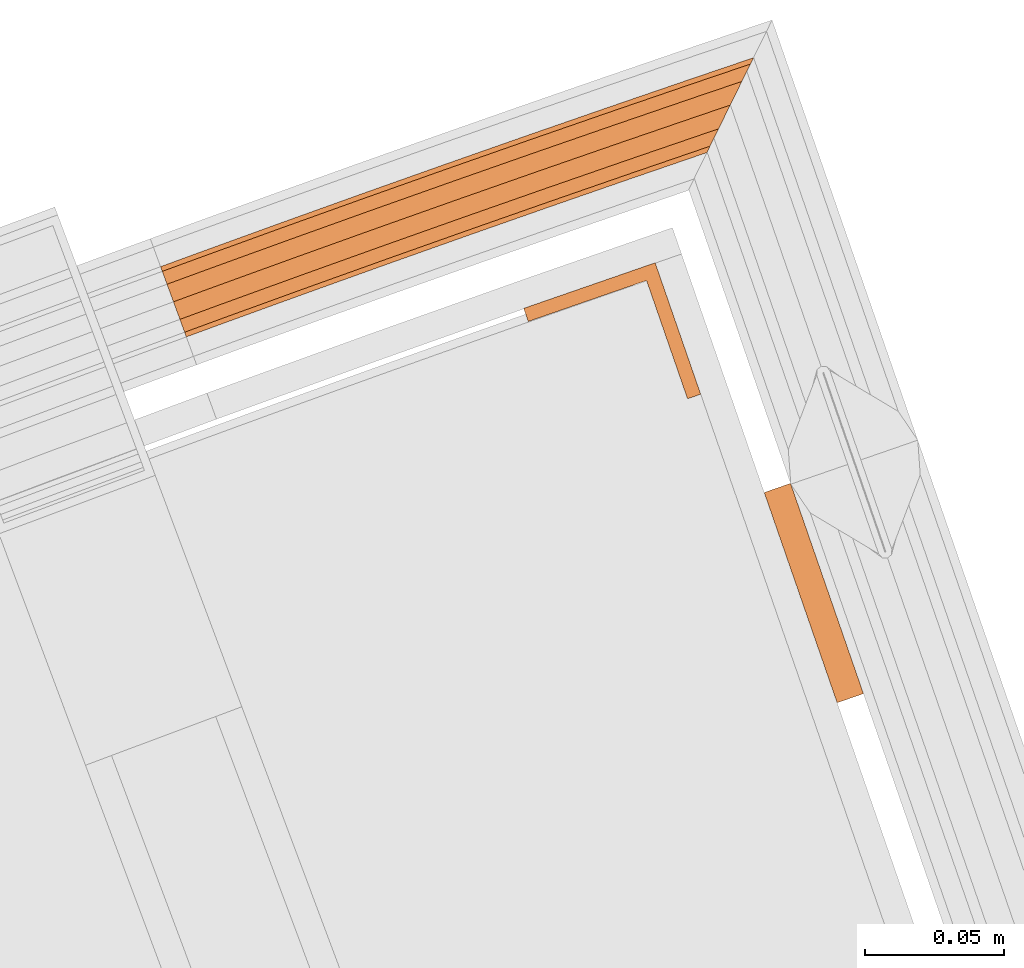
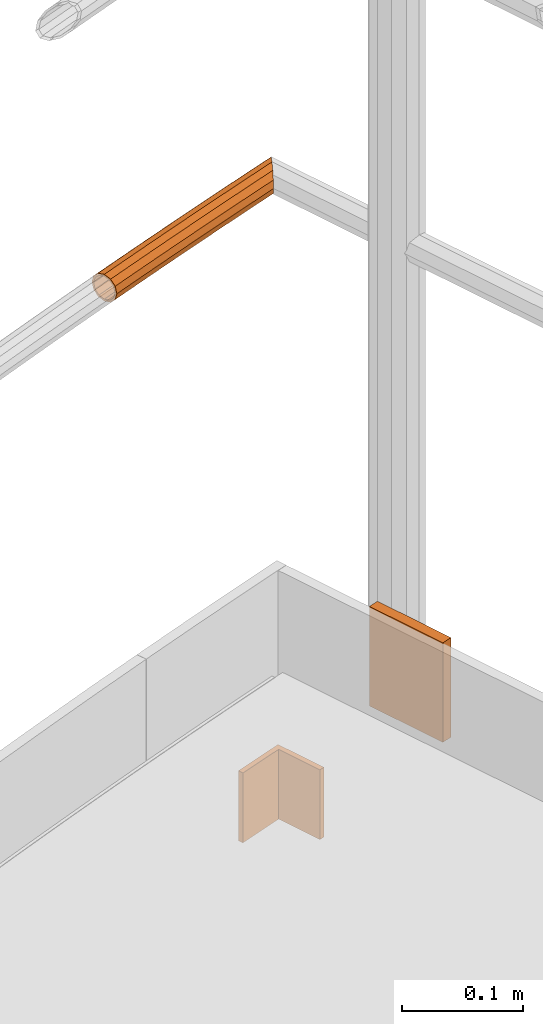
# One storey, part 103 of 126: 3 proxies.
"""IFC2X3 building model written with IfcOpenShell, lengths in millimetres."""

from ifc_helpers import new_model, si_unit, origin, origin_with_axes, place, context, project, spatial, faceted_brep, material, element, save


model = new_model("IFC2X3")

# Units and contexts
context_of_model_1 = context(None, 3, precision=0.1, world=origin())
context_of_model_2 = context(None, 3, precision=0.1, world=origin())
ifc_project = project(units=[si_unit("LENGTHUNIT", "METRE", prefix="MILLI"), si_unit("AREAUNIT", "SQUARE_METRE", prefix="CENTI"), si_unit("VOLUMEUNIT", "CUBIC_METRE", prefix="CENTI"), si_unit("MASSUNIT", "GRAM", prefix="KILO")], contexts=[context_of_model_1, context_of_model_2])

# Site, building, storey
site_placement = place(None, origin_with_axes())
site = spatial("IfcSite", under=ifc_project, at=site_placement, CompositionType="ELEMENT")
building_placement = place(site_placement, origin_with_axes())
building = spatial("IfcBuilding", under=site, at=building_placement, CompositionType="ELEMENT")
storey_placement = place(building_placement, origin_with_axes())
storey = spatial("IfcBuildingStorey", under=building, at=storey_placement, CompositionType="ELEMENT")

# Proxies
ifc_material = material(Name="S235JRG2")
proxy_1_placement = place(storey_placement, origin_with_axes())
element("IfcBuildingElementProxy", 1, at=proxy_1_placement, inside=storey, material=ifc_material, context=context_of_model_2, shape_type="Brep", body=[
    faceted_brep([(4962.9055, 16344.965, 11538.155), (4963.523, 16343.272, 11531.43), (4948.9781, 16337.938, 11531.43), (4948.3576, 16339.63, 11538.155), (4965.21, 16338.647, 11526.507), (4950.6731, 16333.316, 11526.507), (4967.5145, 16332.33, 11524.705), (4952.9885, 16327.002, 11524.705), (4969.819, 16326.012, 11526.507), (4955.304, 16320.689, 11526.507), (4971.506, 16321.387, 11531.43), (4956.999, 16316.066, 11531.43), (4972.1235, 16319.694, 11538.155), (4957.6195, 16314.375, 11538.155), (4971.506, 16321.387, 11544.88), (4956.999, 16316.066, 11544.88), (4969.819, 16326.012, 11549.803), (4955.304, 16320.689, 11549.803), (4967.5145, 16332.33, 11551.605), (4952.9885, 16327.002, 11551.605), (4965.21, 16338.647, 11549.803), (4950.6731, 16333.316, 11549.803), (4963.523, 16343.272, 11544.88), (4948.9781, 16337.938, 11544.88), (4963.5909, 16343.086, 11538.155), (4964.1165, 16341.645, 11543.88), (4949.5744, 16336.312, 11543.88), (4949.0462, 16337.752, 11538.155), (4965.5527, 16337.708, 11548.071), (4951.0174, 16332.377, 11548.071), (4967.5145, 16332.33, 11549.605), (4952.9885, 16327.002, 11549.605), (4969.4763, 16326.951, 11548.071), (4954.9597, 16321.627, 11548.071), (4970.9125, 16323.014, 11543.88), (4956.4027, 16317.693, 11543.88), (4971.4382, 16321.573, 11538.155), (4956.9308, 16316.252, 11538.155), (4970.9125, 16323.014, 11532.43), (4956.4027, 16317.693, 11532.43), (4969.4763, 16326.951, 11528.239), (4954.9597, 16321.627, 11528.239), (4967.5145, 16332.33, 11526.705), (4952.9885, 16327.002, 11526.705), (4965.5527, 16337.708, 11528.239), (4951.0174, 16332.377, 11528.239), (4964.1165, 16341.645, 11532.43), (4949.5744, 16336.312, 11532.43), (4992.036, 16355.533, 11538.155), (4992.6475, 16353.838, 11531.43), (4994.3184, 16349.208, 11526.507), (4996.6008, 16342.882, 11524.705), (4998.8833, 16336.556, 11526.507), (5000.5541, 16331.925, 11531.43), (5001.1657, 16330.23, 11538.155), (5000.5541, 16331.925, 11544.88), (4998.8833, 16336.556, 11549.803), (4996.6008, 16342.882, 11551.605), (4994.3184, 16349.208, 11549.803), (4992.6475, 16353.838, 11544.88), (4992.7148, 16353.652, 11538.155), (4993.2354, 16352.209, 11543.88), (4994.6578, 16348.267, 11548.071), (4996.6008, 16342.882, 11549.605), (4998.5439, 16337.496, 11548.071), (4999.9663, 16333.554, 11543.88), (5000.4869, 16332.111, 11538.155), (4999.9663, 16333.554, 11532.43), (4998.5439, 16337.496, 11528.239), (4996.6008, 16342.882, 11526.705), (4994.6578, 16348.267, 11528.239), (4993.2354, 16352.209, 11532.43), (5021.2031, 16366.0, 11538.155), (5021.8088, 16364.303, 11531.43), (5023.4635, 16359.666, 11526.507), (5025.7238, 16353.332, 11524.705), (5027.9841, 16346.998, 11526.507), (5029.6388, 16342.362, 11531.43), (5030.2445, 16340.665, 11538.155), (5029.6388, 16342.362, 11544.88), (5027.9841, 16346.998, 11549.803), (5025.7238, 16353.332, 11551.605), (5023.4635, 16359.666, 11549.803), (5021.8088, 16364.303, 11544.88), (5021.8753, 16364.116, 11538.155), (5022.3909, 16362.671, 11543.88), (5023.7996, 16358.724, 11548.071), (5025.7238, 16353.332, 11549.605), (5027.648, 16347.94, 11548.071), (5029.0567, 16343.993, 11543.88), (5029.5723, 16342.548, 11538.155), (5029.0567, 16343.993, 11532.43), (5027.648, 16347.94, 11528.239), (5025.7238, 16353.332, 11526.705), (5023.7996, 16358.724, 11528.239), (5022.3909, 16362.671, 11532.43), (5050.4066, 16376.364, 11538.155), (5051.0064, 16374.665, 11531.43), (5052.6448, 16370.022, 11526.507), (5054.8831, 16363.681, 11524.705), (5057.1213, 16357.339, 11526.507), (5058.7598, 16352.697, 11531.43), (5059.3595, 16350.998, 11538.155), (5058.7598, 16352.697, 11544.88), (5057.1213, 16357.339, 11549.803), (5054.8831, 16363.681, 11551.605), (5052.6448, 16370.022, 11549.803), (5051.0064, 16374.665, 11544.88), (5051.0723, 16374.478, 11538.155), (5051.5828, 16373.031, 11543.88), (5052.9777, 16369.08, 11548.071), (5054.8831, 16363.681, 11549.605), (5056.7885, 16358.282, 11548.071), (5058.1833, 16354.33, 11543.88), (5058.6939, 16352.884, 11538.155), (5058.1833, 16354.33, 11532.43), (5056.7885, 16358.282, 11528.239), (5054.8831, 16363.681, 11526.705), (5052.9777, 16369.08, 11528.239), (5051.5828, 16373.031, 11532.43), (5079.6461, 16386.626, 11538.155), (5080.2399, 16384.925, 11531.43), (5081.8622, 16380.277, 11526.507), (5084.0783, 16373.928, 11524.705), (5086.2943, 16367.578, 11526.507), (5087.9166, 16362.93, 11531.43), (5088.5104, 16361.229, 11538.155), (5087.9166, 16362.93, 11544.88), (5086.2943, 16367.578, 11549.803), (5084.0783, 16373.928, 11551.605), (5081.8622, 16380.277, 11549.803), (5080.2399, 16384.925, 11544.88), (5080.3052, 16384.738, 11538.155), (5080.8107, 16383.29, 11543.88), (5082.1917, 16379.333, 11548.071), (5084.0783, 16373.928, 11549.605), (5085.9648, 16368.522, 11548.071), (5087.3459, 16364.566, 11543.88), (5087.8514, 16363.117, 11538.155), (5087.3459, 16364.566, 11532.43), (5085.9648, 16368.522, 11528.239), (5084.0783, 16373.928, 11526.705), (5082.1917, 16379.333, 11528.239), (5080.8107, 16383.29, 11532.43), (5108.9213, 16396.787, 11538.155), (5109.5092, 16395.084, 11531.43), (5111.1152, 16390.43, 11526.507), (5113.3091, 16384.073, 11524.705), (5115.503, 16377.716, 11526.507), (5117.109, 16373.062, 11531.43), (5117.6969, 16371.359, 11538.155), (5117.109, 16373.062, 11544.88), (5115.503, 16377.716, 11549.803), (5113.3091, 16384.073, 11551.605), (5111.1152, 16390.43, 11549.803), (5109.5092, 16395.084, 11544.88), (5109.5738, 16394.896, 11538.155), (5110.0742, 16393.446, 11543.88), (5111.4414, 16389.484, 11548.071), (5113.3091, 16384.073, 11549.605), (5115.1767, 16378.661, 11548.071), (5116.544, 16374.699, 11543.88), (5117.0444, 16373.249, 11538.155), (5116.544, 16374.699, 11532.43), (5115.1767, 16378.661, 11528.239), (5113.3091, 16384.073, 11526.705), (5111.4414, 16389.484, 11528.239), (5110.0742, 16393.446, 11532.43), (5138.2318, 16406.845, 11538.155), (5138.8137, 16405.14, 11531.43), (5140.4034, 16400.48, 11526.507), (5142.5751, 16394.116, 11524.705), (5144.7468, 16387.751, 11526.507), (5146.177, 16383.559, 11530.936), (5145.868, 16382.931, 11531.43), (5144.7412, 16380.639, 11538.155), (5145.868, 16382.931, 11544.88), (5146.177, 16383.559, 11545.374), (5144.7468, 16387.751, 11549.803), (5142.5751, 16394.116, 11551.605), (5140.4034, 16400.48, 11549.803), (5138.8137, 16405.14, 11544.88), (5138.8776, 16404.952, 11538.155), (5139.373, 16403.5, 11543.88), (5140.7264, 16399.534, 11548.071), (5142.5751, 16394.116, 11549.605), (5144.4239, 16388.697, 11548.071), (5145.7773, 16384.731, 11543.88), (5146.177, 16383.559, 11539.26), (5145.9918, 16383.183, 11538.155), (5146.177, 16383.559, 11537.05), (5145.7773, 16384.731, 11532.43), (5144.4239, 16388.697, 11528.239), (5142.5751, 16394.116, 11526.705), (5140.7264, 16399.534, 11528.239), (5139.373, 16403.5, 11532.43), (5161.509, 16414.742, 11538.155), (5160.3861, 16412.458, 11531.43), (5157.3183, 16406.219, 11526.507), (5153.1276, 16397.696, 11524.705), (5148.9369, 16389.172, 11526.507), (5148.9369, 16389.172, 11549.803), (5153.1276, 16397.696, 11551.605), (5157.3183, 16406.219, 11549.803), (5160.3861, 16412.458, 11544.88), (5160.2627, 16412.207, 11538.155), (5159.3067, 16410.263, 11543.88), (5156.6951, 16404.951, 11548.071), (5153.1276, 16397.696, 11549.605), (5149.56, 16390.44, 11548.071), (5146.9484, 16385.128, 11543.88), (5146.9484, 16385.128, 11532.43), (5149.56, 16390.44, 11528.239), (5153.1276, 16397.696, 11526.705), (5156.6951, 16404.951, 11528.239), (5159.3067, 16410.263, 11532.43)], [[[0, 1, 2, 3]], [[1, 4, 5, 2]], [[4, 6, 7, 5]], [[6, 8, 9, 7]], [[8, 10, 11, 9]], [[10, 12, 13, 11]], [[12, 14, 15, 13]], [[14, 16, 17, 15]], [[16, 18, 19, 17]], [[18, 20, 21, 19]], [[20, 22, 23, 21]], [[0, 3, 23, 22]], [[24, 25, 26, 27]], [[25, 28, 29, 26]], [[28, 30, 31, 29]], [[30, 32, 33, 31]], [[32, 34, 35, 33]], [[34, 36, 37, 35]], [[36, 38, 39, 37]], [[38, 40, 41, 39]], [[40, 42, 43, 41]], [[42, 44, 45, 43]], [[44, 46, 47, 45]], [[24, 27, 47, 46]], [[0, 48, 49, 1]], [[1, 49, 50, 4]], [[4, 50, 51, 6]], [[6, 51, 52, 8]], [[8, 52, 53, 10]], [[10, 53, 54, 12]], [[12, 54, 55, 14]], [[14, 55, 56, 16]], [[16, 56, 57, 18]], [[18, 57, 58, 20]], [[20, 58, 59, 22]], [[22, 59, 48, 0]], [[24, 60, 61, 25]], [[25, 61, 62, 28]], [[28, 62, 63, 30]], [[30, 63, 64, 32]], [[32, 64, 65, 34]], [[34, 65, 66, 36]], [[36, 66, 67, 38]], [[38, 67, 68, 40]], [[40, 68, 69, 42]], [[42, 69, 70, 44]], [[44, 70, 71, 46]], [[46, 71, 60, 24]], [[48, 72, 73, 49]], [[49, 73, 74, 50]], [[50, 74, 75, 51]], [[51, 75, 76, 52]], [[52, 76, 77, 53]], [[53, 77, 78, 54]], [[54, 78, 79, 55]], [[55, 79, 80, 56]], [[56, 80, 81, 57]], [[57, 81, 82, 58]], [[58, 82, 83, 59]], [[59, 83, 72, 48]], [[60, 84, 85, 61]], [[61, 85, 86, 62]], [[62, 86, 87, 63]], [[63, 87, 88, 64]], [[64, 88, 89, 65]], [[65, 89, 90, 66]], [[66, 90, 91, 67]], [[67, 91, 92, 68]], [[68, 92, 93, 69]], [[69, 93, 94, 70]], [[70, 94, 95, 71]], [[71, 95, 84, 60]], [[72, 96, 97, 73]], [[73, 97, 98, 74]], [[74, 98, 99, 75]], [[75, 99, 100, 76]], [[76, 100, 101, 77]], [[77, 101, 102, 78]], [[78, 102, 103, 79]], [[79, 103, 104, 80]], [[80, 104, 105, 81]], [[81, 105, 106, 82]], [[82, 106, 107, 83]], [[83, 107, 96, 72]], [[84, 108, 109, 85]], [[85, 109, 110, 86]], [[86, 110, 111, 87]], [[87, 111, 112, 88]], [[88, 112, 113, 89]], [[89, 113, 114, 90]], [[90, 114, 115, 91]], [[91, 115, 116, 92]], [[92, 116, 117, 93]], [[93, 117, 118, 94]], [[94, 118, 119, 95]], [[95, 119, 108, 84]], [[96, 120, 121, 97]], [[97, 121, 122, 98]], [[98, 122, 123, 99]], [[99, 123, 124, 100]], [[100, 124, 125, 101]], [[101, 125, 126, 102]], [[102, 126, 127, 103]], [[103, 127, 128, 104]], [[104, 128, 129, 105]], [[105, 129, 130, 106]], [[106, 130, 131, 107]], [[107, 131, 120, 96]], [[108, 132, 133, 109]], [[109, 133, 134, 110]], [[110, 134, 135, 111]], [[111, 135, 136, 112]], [[112, 136, 137, 113]], [[113, 137, 138, 114]], [[114, 138, 139, 115]], [[115, 139, 140, 116]], [[116, 140, 141, 117]], [[117, 141, 142, 118]], [[118, 142, 143, 119]], [[119, 143, 132, 108]], [[120, 144, 145, 121]], [[121, 145, 146, 122]], [[122, 146, 147, 123]], [[123, 147, 148, 124]], [[124, 148, 149, 125]], [[125, 149, 150, 126]], [[126, 150, 151, 127]], [[127, 151, 152, 128]], [[128, 152, 153, 129]], [[129, 153, 154, 130]], [[130, 154, 155, 131]], [[131, 155, 144, 120]], [[132, 156, 157, 133]], [[133, 157, 158, 134]], [[134, 158, 159, 135]], [[135, 159, 160, 136]], [[136, 160, 161, 137]], [[137, 161, 162, 138]], [[138, 162, 163, 139]], [[139, 163, 164, 140]], [[140, 164, 165, 141]], [[141, 165, 166, 142]], [[142, 166, 167, 143]], [[143, 167, 156, 132]], [[144, 168, 169, 145]], [[145, 169, 170, 146]], [[146, 170, 171, 147]], [[147, 171, 172, 148]], [[149, 148, 172, 173, 174]], [[149, 174, 175, 150]], [[150, 175, 176, 151]], [[151, 176, 177, 178, 152]], [[152, 178, 179, 153]], [[153, 179, 180, 154]], [[154, 180, 181, 155]], [[155, 181, 168, 144]], [[156, 182, 183, 157]], [[157, 183, 184, 158]], [[158, 184, 185, 159]], [[159, 185, 186, 160]], [[160, 186, 187, 161]], [[162, 161, 187, 188, 189]], [[162, 189, 190, 191, 163]], [[163, 191, 192, 164]], [[164, 192, 193, 165]], [[165, 193, 194, 166]], [[166, 194, 195, 167]], [[167, 195, 182, 156]], [[168, 196, 197, 169]], [[169, 197, 198, 170]], [[170, 198, 199, 171]], [[171, 199, 200, 172]], [[172, 200, 173]], [[177, 201, 178]], [[178, 201, 202, 179]], [[179, 202, 203, 180]], [[180, 203, 204, 181]], [[168, 181, 204, 196]], [[182, 205, 206, 183]], [[183, 206, 207, 184]], [[184, 207, 208, 185]], [[185, 208, 209, 186]], [[186, 209, 210, 187]], [[187, 210, 188]], [[190, 211, 191]], [[191, 211, 212, 192]], [[192, 212, 213, 193]], [[193, 213, 214, 194]], [[194, 214, 215, 195]], [[182, 195, 215, 205]], [[13, 15, 17, 19, 21, 23, 3, 2, 5, 7, 9, 11], [26, 29, 31, 33, 35, 37, 39, 41, 43, 45, 47, 27]], [[175, 174, 173, 200, 199, 198, 197, 196, 204, 203, 202, 201, 177, 176], [188, 210, 209, 208, 207, 206, 205, 215, 214, 213, 212, 211, 190, 189]]]),
])
proxy_2_placement = place(storey_placement, origin_with_axes())
element("IfcBuildingElementProxy", 2, at=proxy_2_placement, inside=storey, material=ifc_material, Name="HANDLAUF", context=context_of_model_2, shape_type="Brep", body=[
    faceted_brep([(5165.3673, 16258.451, 11085.15), (5174.8156, 16261.726, 11085.15), (5201.0184, 16186.139, 11085.15), (5191.57, 16182.864, 11085.15), (5165.3673, 16258.451, 11185.15), (5191.57, 16182.864, 11185.15), (5201.0184, 16186.139, 11185.15), (5174.8156, 16261.726, 11185.15)], [[[0, 1, 2, 3]], [[4, 5, 6, 7]], [[0, 4, 7, 1]], [[1, 7, 6, 2]], [[2, 6, 5, 3]], [[3, 5, 4, 0]]]),
])
proxy_3_placement = place(storey_placement, origin_with_axes())
element("IfcBuildingElementProxy", 3, at=proxy_3_placement, inside=storey, material=ifc_material, Name="HANDLAUF", context=context_of_model_2, shape_type="Brep", body=[
    faceted_brep([(5078.9032, 16324.66, 10940.0), (5078.9032, 16324.66, 11010.15), (5126.1494, 16341.025, 11010.15), (5126.1494, 16341.025, 10940.0), (5080.5396, 16319.936, 10940.0), (5080.5396, 16319.936, 11010.15), (5123.0612, 16334.664, 10940.0), (5123.0612, 16334.664, 11010.15), (5137.7893, 16292.142, 10940.0), (5137.7893, 16292.142, 11010.15), (5142.5139, 16293.779, 10940.0), (5142.5139, 16293.779, 11010.15)], [[[0, 1, 2, 3]], [[0, 4, 5, 1]], [[4, 6, 7, 5]], [[6, 8, 9, 7]], [[8, 10, 11, 9]], [[2, 11, 10, 3]], [[3, 10, 8, 6, 4, 0]], [[9, 11, 2, 1, 5, 7]]]),
])

save(model, "model.ifc")
